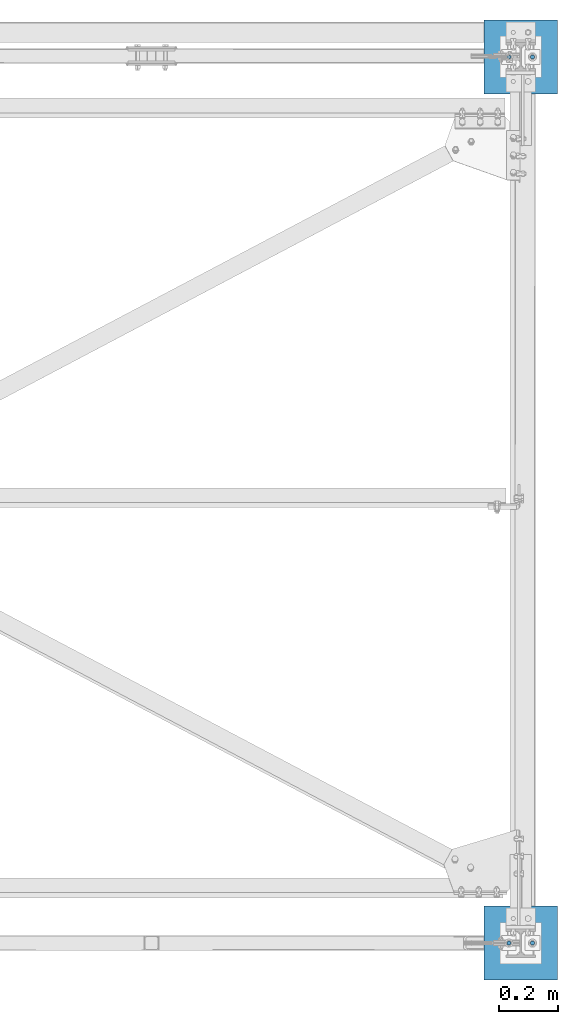
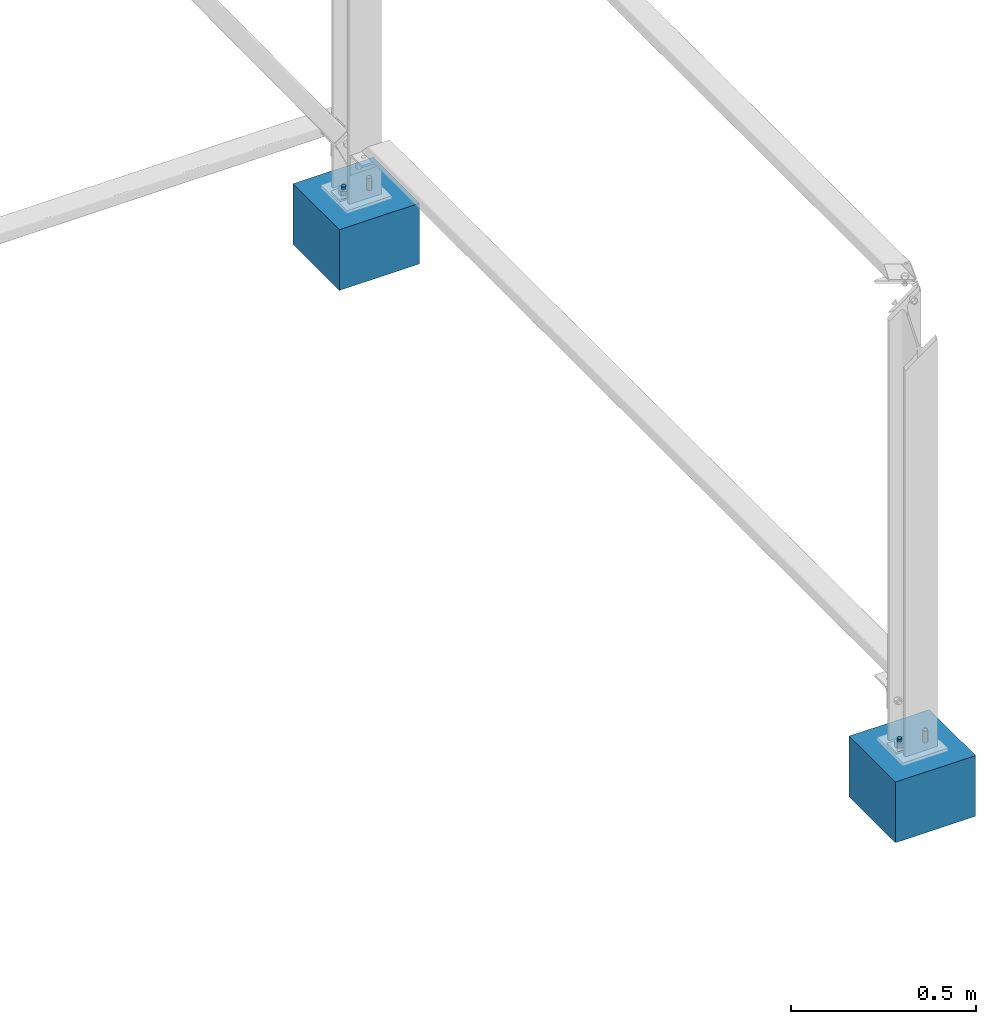
# One storey, part 4 of 28: 6 columns, 6 elements without a shape of their own.
"""IFC2X3 building model written with IfcOpenShell, lengths in millimetres."""

from ifc_helpers import new_model, si_unit, frame, origin_with_axes, origin_2d_with_axis, place, context, subcontext, project, spatial, rectangle, circle, extrude, material, type_object, element, aggregate, save


model = new_model("IFC2X3")

# Units and contexts
model_context = context("Model", 3, precision=1e-05, world=origin_with_axes())
body_context = subcontext(model_context, "Body", "Model", "MODEL_VIEW")
ifc_project = project(units=[si_unit("LENGTHUNIT", "METRE", prefix="MILLI"), si_unit("AREAUNIT", "SQUARE_METRE"), si_unit("VOLUMEUNIT", "CUBIC_METRE"), si_unit("MASSUNIT", "GRAM", prefix="KILO"), si_unit("TIMEUNIT", "SECOND"), si_unit("PLANEANGLEUNIT", "RADIAN"), si_unit("SOLIDANGLEUNIT", "STERADIAN"), si_unit("THERMODYNAMICTEMPERATUREUNIT", "DEGREE_CELSIUS"), si_unit("LUMINOUSINTENSITYUNIT", "LUMEN")], contexts=[model_context])

# Site, building, storey
site_placement = place(None, origin_with_axes())
site = spatial("IfcSite", under=ifc_project, at=site_placement, CompositionType="ELEMENT")
building_placement = place(site_placement, origin_with_axes())
building = spatial("IfcBuilding", under=site, at=building_placement, Name="Undefined", CompositionType="ELEMENT")
storey_placement = place(building_placement, origin_with_axes())
storey = spatial("IfcBuildingStorey", under=building, at=storey_placement, Name="Undefined", CompositionType="ELEMENT", Elevation=0.0)

# Assembly, column
assembly_1_placement = place(storey_placement, origin_with_axes())
assembly_1 = element("IfcElementAssembly", 1, at=assembly_1_placement, inside=storey, AssemblyPlace="NOTDEFINED", PredefinedType="NOTDEFINED")
ifc_material_1 = material(Name="STEEL/S235JR")
column_type_1 = type_object("IfcColumnType", Name="D14", PredefinedType="NOTDEFINED")
column_1_placement = place(assembly_1_placement, frame((4960.00000000035, 3000.00000000094, 239.999895901093), z_axis=(0.0, 0.0, -1.0), x_axis=(0.0, -1.0, 0.0)))
column_1 = element("IfcColumn", 2, at=column_1_placement, type_object=column_type_1, material=ifc_material_1, context=body_context, shape_type="SweptSolid", body=[
    extrude(circle(Radius=7.0, at=origin_2d_with_axis()), frame((0.0, 0.0, 200.0), z_axis=(0.0, 0.0, -1.0), x_axis=(0.0, 1.0, 0.0)), (0.0, 0.0, 1.0), 200.0),
])
aggregate(assembly_1, [column_1])

assembly_2_placement = place(storey_placement, origin_with_axes())
assembly_2 = element("IfcElementAssembly", 3, at=assembly_2_placement, inside=storey, AssemblyPlace="NOTDEFINED", PredefinedType="NOTDEFINED")
column_2_placement = place(assembly_2_placement, frame((5040.00000000035, 3000.00000000094, 239.999895901093), z_axis=(0.0, 0.0, -1.0), x_axis=(0.0, 1.0, 0.0)))
column_2 = element("IfcColumn", 4, at=column_2_placement, type_object=column_type_1, material=ifc_material_1, context=body_context, shape_type="SweptSolid", body=[
    extrude(circle(Radius=7.0, at=origin_2d_with_axis()), frame((0.0, 0.0, 200.0), z_axis=(0.0, 0.0, -1.0), x_axis=(0.0, 1.0, 0.0)), (0.0, 0.0, 1.0), 200.0),
])
aggregate(assembly_2, [column_2])

assembly_3_placement = place(storey_placement, origin_with_axes())
assembly_3 = element("IfcElementAssembly", 5, at=assembly_3_placement, inside=storey, AssemblyPlace="NOTDEFINED", PredefinedType="NOTDEFINED")
column_3_placement = place(assembly_3_placement, frame((4960.00000000035, 9.38356947699504e-10, 239.999895901477), z_axis=(0.0, 0.0, -1.0), x_axis=(0.0, -1.0, 0.0)))
column_3 = element("IfcColumn", 6, at=column_3_placement, type_object=column_type_1, material=ifc_material_1, context=body_context, shape_type="SweptSolid", body=[
    extrude(circle(Radius=7.0, at=origin_2d_with_axis()), frame((0.0, 0.0, 200.0), z_axis=(0.0, 0.0, -1.0), x_axis=(0.0, 1.0, 0.0)), (0.0, 0.0, 1.0), 200.0),
])
aggregate(assembly_3, [column_3])

assembly_4_placement = place(storey_placement, origin_with_axes())
assembly_4 = element("IfcElementAssembly", 7, at=assembly_4_placement, inside=storey, AssemblyPlace="NOTDEFINED", PredefinedType="NOTDEFINED")
column_4_placement = place(assembly_4_placement, frame((5040.00000000035, 9.38356947699504e-10, 239.999895901477), z_axis=(0.0, 0.0, -1.0), x_axis=(0.0, 1.0, 0.0)))
column_4 = element("IfcColumn", 8, at=column_4_placement, type_object=column_type_1, material=ifc_material_1, context=body_context, shape_type="SweptSolid", body=[
    extrude(circle(Radius=7.0, at=origin_2d_with_axis()), frame((0.0, 0.0, 200.0), z_axis=(0.0, 0.0, -1.0), x_axis=(0.0, 1.0, 0.0)), (0.0, 0.0, 1.0), 200.0),
])
aggregate(assembly_4, [column_4])

assembly_5_placement = place(storey_placement, origin_with_axes())
assembly_5 = element("IfcElementAssembly", 9, at=assembly_5_placement, inside=storey, Name="POTEAU", AssemblyPlace="NOTDEFINED", PredefinedType="NOTDEFINED")
ifc_material_2 = material(Name="CONCRETE/C25/30")
column_type_2 = type_object("IfcColumnType", PredefinedType="NOTDEFINED")
column_5_placement = place(assembly_5_placement, frame((5000.0, 3000.0, 0.0), z_axis=(0.0, 0.0, 1.0), x_axis=(0.0, 1.0, 0.0)))
column_5 = element("IfcColumn", 10, at=column_5_placement, type_object=column_type_2, material=ifc_material_2, Name="POTEAU", context=body_context, shape_type="SweptSolid", body=[
    extrude(rectangle(XDim=250.0, YDim=250.0, at=origin_2d_with_axis()), frame((0.0, 0.0, 200.0), z_axis=(0.0, 0.0, -1.0), x_axis=(0.0, 1.0, 0.0)), (0.0, 0.0, 1.0), 200.0),
])
aggregate(assembly_5, [column_5])

assembly_6_placement = place(storey_placement, origin_with_axes())
assembly_6 = element("IfcElementAssembly", 11, at=assembly_6_placement, inside=storey, Name="POTEAU", AssemblyPlace="NOTDEFINED", PredefinedType="NOTDEFINED")
column_6_placement = place(assembly_6_placement, frame((5000.0, 0.0, 0.0), z_axis=(0.0, 0.0, 1.0), x_axis=(0.0, 1.0, 0.0)))
column_6 = element("IfcColumn", 12, at=column_6_placement, type_object=column_type_2, material=ifc_material_2, Name="POTEAU", context=body_context, shape_type="SweptSolid", body=[
    extrude(rectangle(XDim=250.0, YDim=250.0, at=origin_2d_with_axis()), frame((0.0, 0.0, 200.0), z_axis=(0.0, 0.0, -1.0), x_axis=(0.0, 1.0, 0.0)), (0.0, 0.0, 1.0), 200.0),
])
aggregate(assembly_6, [column_6])

save(model, "model.ifc")
